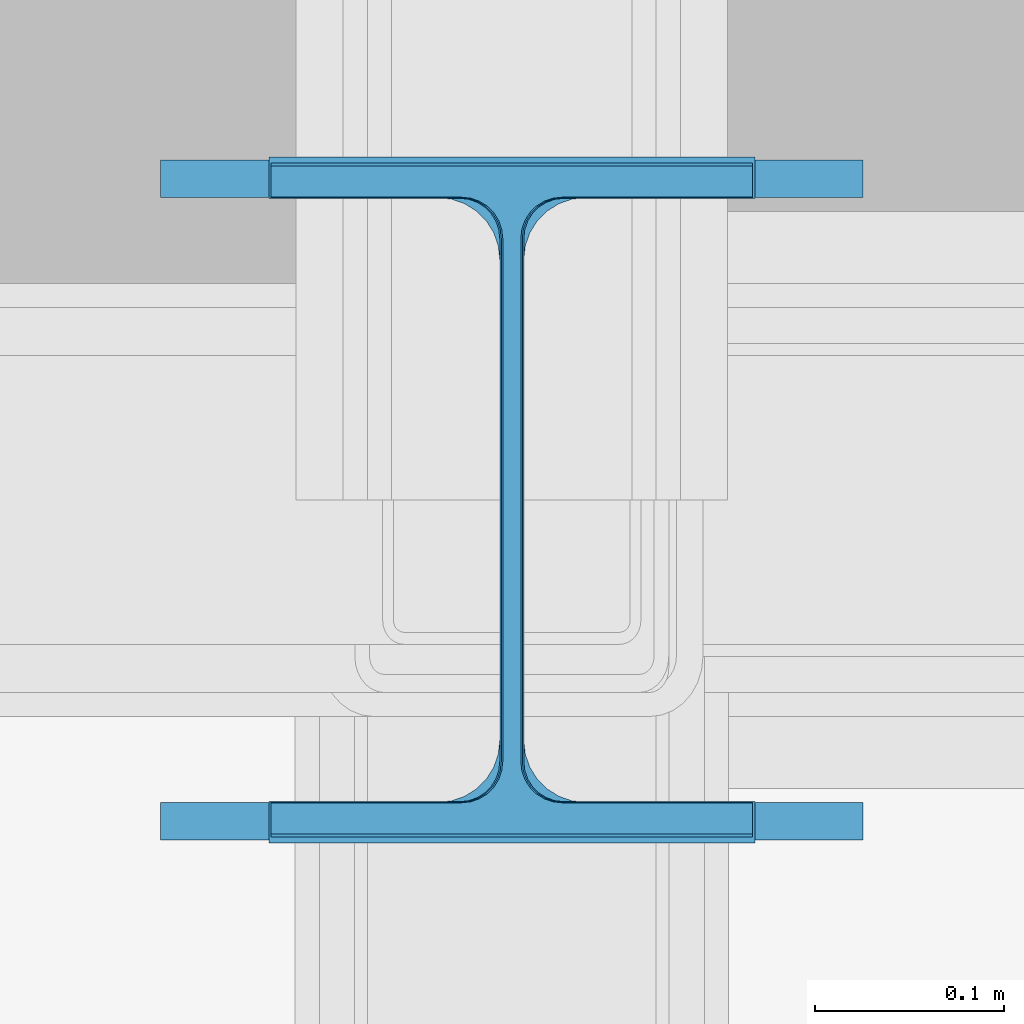
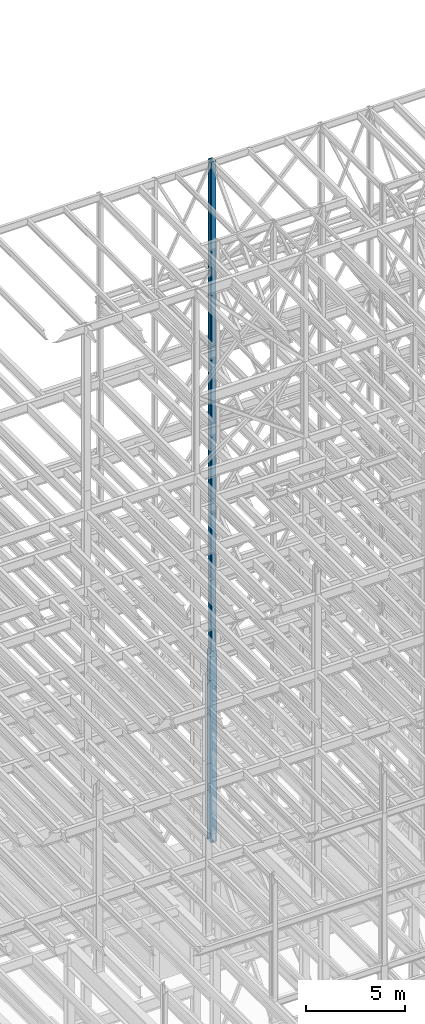
# One storey, part 48 of 150: 4 columns.
"""IFC2X3 building model written with IfcOpenShell, lengths in millimetres."""

from ifc_helpers import new_model, si_unit, frame, origin_with_axes, origin_2d_with_axis, place, context, subcontext, project, spatial, i_section, extrude, material, type_object, element, save


model = new_model("IFC2X3")

# Units and contexts
model_context = context("Model", 3, precision=1e-05, world=origin_with_axes())
body_context = subcontext(model_context, "Body", "Model", "MODEL_VIEW")
ifc_project = project(units=[si_unit("LENGTHUNIT", "METRE", prefix="MILLI"), si_unit("AREAUNIT", "SQUARE_METRE"), si_unit("VOLUMEUNIT", "CUBIC_METRE"), si_unit("MASSUNIT", "GRAM", prefix="KILO"), si_unit("TIMEUNIT", "SECOND"), si_unit("PLANEANGLEUNIT", "RADIAN"), si_unit("SOLIDANGLEUNIT", "STERADIAN"), si_unit("THERMODYNAMICTEMPERATUREUNIT", "DEGREE_CELSIUS"), si_unit("LUMINOUSINTENSITYUNIT", "LUMEN")], contexts=[model_context])

# Site, building, storey
site_placement = place(None, origin_with_axes())
site = spatial("IfcSite", under=ifc_project, at=site_placement, CompositionType="ELEMENT")
building_placement = place(site_placement, origin_with_axes())
building = spatial("IfcBuilding", under=site, at=building_placement, Name="Undefined", CompositionType="ELEMENT")
storey_placement = place(building_placement, origin_with_axes())
storey = spatial("IfcBuildingStorey", under=building, at=storey_placement, Name="Undefined", CompositionType="ELEMENT", Elevation=0.0)

# Columns
ifc_material = material(Name="STEEL/A992")
column_type_1 = type_object("IfcColumnType", Name="W14X61", PredefinedType="NOTDEFINED")
column_1_placement = place(storey_placement, frame((56591.2, 31877.0, 54483.0), z_axis=(0.0, 0.0, 1.0), x_axis=(1.0, 0.0, 0.0)))
element("IfcColumn", 1, at=column_1_placement, inside=storey, type_object=column_type_1, material=ifc_material, Name="COLUMN", ObjectType="W14X61", context=body_context, shape_type="SweptSolid", body=[
    extrude(i_section(OverallWidth=254.0, OverallDepth=352.425, WebThickness=9.5249, FlangeThickness=16.383, FilletRadius=21.717, at=origin_2d_with_axis()), frame((0.0, 0.0, 11430.0), z_axis=(0.0, 0.0, -1.0), x_axis=(-1.0, 0.0, 0.0)), (0.0, 0.0, 1.0), 11430.0),
])
column_type_2 = type_object("IfcColumnType", Name="W14X68", PredefinedType="NOTDEFINED")
column_2_placement = place(storey_placement, frame((56591.2, 31877.0, 45034.2), z_axis=(0.0, 0.0, 1.0), x_axis=(1.0, 0.0, 0.0)))
element("IfcColumn", 2, at=column_2_placement, inside=storey, type_object=column_type_2, material=ifc_material, Name="COLUMN", ObjectType="W14X68", context=body_context, shape_type="SweptSolid", body=[
    extrude(i_section(OverallWidth=254.0, OverallDepth=355.6, WebThickness=11.1125, FlangeThickness=18.288, FilletRadius=21.3994, at=origin_2d_with_axis()), frame((0.0, 0.0, 9448.8), z_axis=(0.0, 0.0, -1.0), x_axis=(-1.0, 0.0, 0.0)), (0.0, 0.0, 1.0), 9448.8),
])
column_type_3 = type_object("IfcColumnType", Name="W14X99", PredefinedType="NOTDEFINED")
column_3_placement = place(storey_placement, frame((56591.2, 31877.0, 23774.4), z_axis=(0.0, 0.0, 1.0), x_axis=(1.0, 0.0, 0.0)))
element("IfcColumn", 3, at=column_3_placement, inside=storey, type_object=column_type_3, material=ifc_material, Name="COLUMN", ObjectType="W14X99", context=body_context, shape_type="SweptSolid", body=[
    extrude(i_section(OverallWidth=370.84, OverallDepth=358.775, WebThickness=12.6999, FlangeThickness=19.812, FilletRadius=32.5755, at=origin_2d_with_axis()), frame((0.0, 0.0, 11811.0), z_axis=(0.0, 0.0, -1.0), x_axis=(-1.0, 0.0, 0.0)), (0.0, 0.0, 1.0), 11811.0),
])
column_type_4 = type_object("IfcColumnType", Name="W14X82", PredefinedType="NOTDEFINED")
column_4_placement = place(storey_placement, frame((56591.2, 31877.0, 35585.4), z_axis=(0.0, 0.0, 1.0), x_axis=(1.0, 0.0, 0.0)))
element("IfcColumn", 4, at=column_4_placement, inside=storey, type_object=column_type_4, material=ifc_material, Name="COLUMN", ObjectType="W14X82", context=body_context, shape_type="SweptSolid", body=[
    extrude(i_section(OverallWidth=256.54, OverallDepth=361.95, WebThickness=12.6999, FlangeThickness=21.717, FilletRadius=21.1455, at=origin_2d_with_axis()), frame((0.0, 0.0, 9448.8), z_axis=(0.0, 0.0, -1.0), x_axis=(-1.0, 0.0, 0.0)), (0.0, 0.0, 1.0), 9448.8),
])

save(model, "model.ifc")
